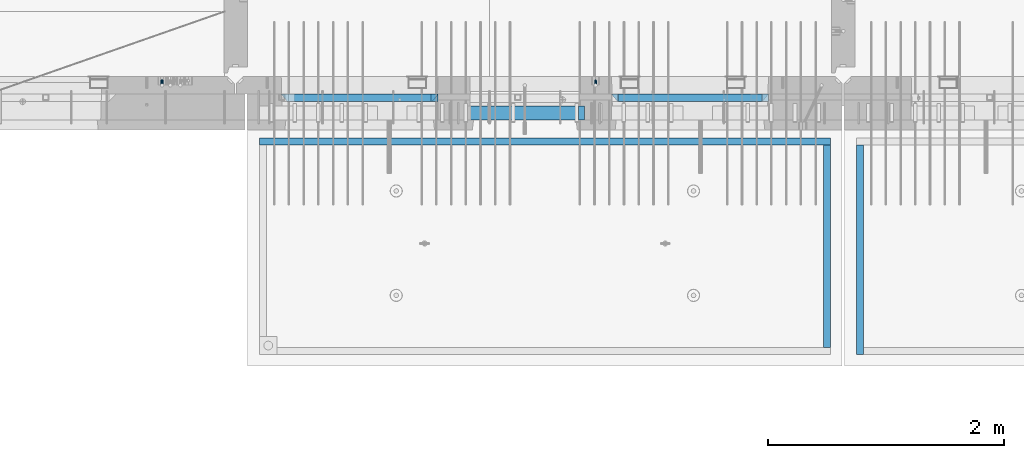
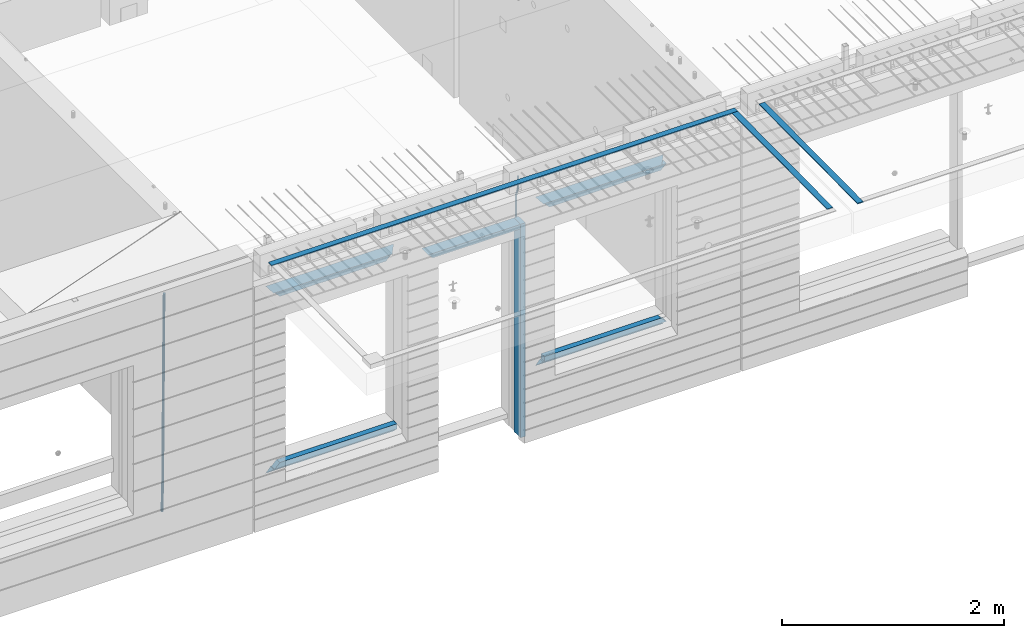
# One storey, part 90 of 334: 15 beams, 4 elements without a shape of their own.
"""IFC2X3 building model written with IfcOpenShell, lengths in millimetres."""

import ifcopenshell
import ifcopenshell.guid

model = None  # the IFC model being written
_history = None  # IfcOwnerHistory: only IFC2X3 demands one
_inside = {}  # id of a spatial element -> (the spatial element, [elements in it])
_under = {}  # id of a project, library or spatial element -> (it, [spatial elements below it])
_declared = {}  # id of a project -> (the project, [libraries it declares])
_typed = {}  # id of a type object -> (the type object, [elements of that type])
_made_of = {}  # id of a material, layer set ... -> (it, [elements and type objects made of it])


def new_model(schema):
    """Start an empty IFC model of exactly this schema.

    Asked for "IFC4X3", IfcOpenShell would pick the latest addendum, in which some entities
    have other attributes; the version numbers below select the first issue.
    IFC2X3 requires an IfcOwnerHistory on every rooted entity: one is made here for all.
    """
    global model, _history
    if schema == "IFC4X3":
        model = ifcopenshell.file(schema_version=(4, 3, 0, 0))
    else:
        model = ifcopenshell.file(schema=schema)
    _inside.clear()
    _under.clear()
    _declared.clear()
    _typed.clear()
    _made_of.clear()
    _history = None
    if model.schema == "IFC2X3":
        org = make("IfcOrganization", Name="unknown")
        user = make(
            "IfcPersonAndOrganization",
            ThePerson=make("IfcPerson", FamilyName="unknown"),
            TheOrganization=org,
        )
        app = make(
            "IfcApplication",
            ApplicationDeveloper=org,
            Version="unknown",
            ApplicationFullName="unknown",
            ApplicationIdentifier="unknown",
        )
        _history = make(
            "IfcOwnerHistory",
            OwningUser=user,
            OwningApplication=app,
            ChangeAction="ADDED",
            CreationDate=0,
        )
    return model


def make(cls, **values):
    """One entity of the class cls with the attributes given. An attribute that is None is left unset."""
    return model.create_entity(
        cls, **{name: value for name, value in values.items() if value is not None}
    )


def rooted(cls, **values):
    """An entity with a GlobalId (a new one), such as an element, a storey or a relation."""
    return make(cls, GlobalId=ifcopenshell.guid.new(), OwnerHistory=_history, **values)


def si_unit(unit_type, name, prefix=None):
    """IfcSIUnit, for example si_unit("LENGTHUNIT", "METRE", prefix="MILLI")."""
    return make("IfcSIUnit", UnitType=unit_type, Prefix=prefix, Name=name)


def assignment(units):
    """IfcUnitAssignment: the units of a project."""
    return None if units is None else make("IfcUnitAssignment", Units=units)


def point(xyz):
    """IfcCartesianPoint."""
    return None if xyz is None else make("IfcCartesianPoint", Coordinates=xyz)


def direction(xyz):
    """IfcDirection."""
    return None if xyz is None else make("IfcDirection", DirectionRatios=xyz)


def frame(location, z_axis=None, x_axis=None):
    """IfcAxis2Placement3D, a coordinate frame: its origin and axes. An axis left out is left unset."""
    return make(
        "IfcAxis2Placement3D",
        Location=point(location),
        Axis=direction(z_axis),
        RefDirection=direction(x_axis),
    )


def origin_with_axes():
    """The frame at (0, 0, 0) with the z axis (0, 0, 1) and the x axis (1, 0, 0) written out."""
    return frame((0.0, 0.0, 0.0), z_axis=(0.0, 0.0, 1.0), x_axis=(1.0, 0.0, 0.0))


def place(relative_to, where):
    """IfcLocalPlacement: puts the frame where relative to a parent placement (None: the world)."""
    return make(
        "IfcLocalPlacement", PlacementRelTo=relative_to, RelativePlacement=where
    )


def context(
    kind, dimensions, precision=None, world=None, true_north=None, identifier=None
):
    """IfcGeometricRepresentationContext, for example the 3D "Model" context."""
    return make(
        "IfcGeometricRepresentationContext",
        ContextIdentifier=identifier,
        ContextType=kind,
        CoordinateSpaceDimension=dimensions,
        Precision=precision,
        WorldCoordinateSystem=world,
        TrueNorth=true_north,
    )


def subcontext(parent, identifier, kind, view, scale=None):
    """IfcGeometricRepresentationSubContext, for example "Body" below "Model"."""
    return make(
        "IfcGeometricRepresentationSubContext",
        ContextIdentifier=identifier,
        ContextType=kind,
        ParentContext=parent,
        TargetScale=scale,
        TargetView=view,
    )


def project(units=None, contexts=None):
    """IfcProject with its units and contexts."""
    return rooted(
        "IfcProject",
        Name="project",
        RepresentationContexts=contexts,
        UnitsInContext=assignment(units),
    )


def spatial(cls, under=None, at=None, **own):
    """A site, building, storey or space (cls), placed at a placement, below another one or the project."""
    s = rooted(cls, ObjectPlacement=at, **own)
    if under is not None:
        _under.setdefault(under.id(), (under, []))[1].append(s)
    return s


def faces_of(points, faces, orient=None, outer=None):
    """IfcFace entities. A face is a list of loops; a loop is a list of indices into points, from 0.

    orient and outer hold one flag for each loop. By default every Orientation is true, the
    first loop of a face is its IfcFaceOuterBound and the others are IfcFaceBound.
    """
    made = []
    for i, loops in enumerate(faces):
        bounds = []
        for j, loop in enumerate(loops):
            is_outer = j == 0 if outer is None else outer[i][j]
            bounds.append(
                make(
                    "IfcFaceOuterBound" if is_outer else "IfcFaceBound",
                    Bound=make("IfcPolyLoop", Polygon=[points[k] for k in loop]),
                    Orientation=True if orient is None else orient[i][j],
                )
            )
        made.append(make("IfcFace", Bounds=bounds))
    return made


def faceted_brep(points, faces, orient=None, outer=None, voids=None):
    """IfcFacetedBrep: a solid bounded by flat faces; with voids (closed shells), ...WithVoids."""
    shared = [point(p) for p in points]
    hull = make("IfcClosedShell", CfsFaces=faces_of(shared, faces, orient, outer))
    if voids is None:
        return make("IfcFacetedBrep", Outer=hull)
    return make(
        "IfcFacetedBrepWithVoids",
        Outer=hull,
        Voids=[
            make(cls, CfsFaces=faces_of(shared, fs, o, b)) for cls, fs, o, b in voids
        ],
    )


def shape(context_of_items, identifier, shape_type, items):
    """IfcShapeRepresentation: the items that make up one representation, for example the "Body"."""
    return make(
        "IfcShapeRepresentation",
        ContextOfItems=context_of_items,
        RepresentationIdentifier=identifier,
        RepresentationType=shape_type,
        Items=items,
    )


def material(Name=None, Category=None):
    """IfcMaterial."""
    return make("IfcMaterial", Name=Name, Category=Category)


def made_of(thing, what):
    """Note that an element or type object is made of a material, layer set ...; save() writes the relation."""
    if what is not None:
        _made_of.setdefault(what.id(), (what, []))[1].append(thing)
    return thing


def type_object(cls, material=None, **own):
    """A type object (cls), such as IfcWallType, which elements share."""
    return made_of(rooted(cls, **own), material)


def element(
    cls,
    number,
    at=None,
    inside=None,
    cuts=None,
    type_object=None,
    material=None,
    context=None,
    identifier="Body",
    shape_type=None,
    held_by="IfcProductDefinitionShape",
    body=None,
    shapes=None,
    **own,
):
    """One element of the class cls, such as IfcWall. Its Tag is "e" and its number.

    at: its placement. inside: the storey or other place that contains it. cuts: it is an
    opening in that element (IfcRelVoidsElement). A single representation is given by context,
    identifier, shape_type and body (its items); several are given by shapes. held_by: the class
    of the entity that holds the representations. save() writes the other relations.
    """
    e = rooted(cls, Tag="e%d" % number, ObjectPlacement=at, **own)
    if body is not None:
        shapes = [shape(context, identifier, shape_type, body)]
    if shapes is not None:
        e.Representation = make(held_by, Representations=shapes)
    if inside is not None:
        _inside.setdefault(inside.id(), (inside, []))[1].append(e)
    if cuts is not None:
        rooted(
            "IfcRelVoidsElement", RelatingBuildingElement=cuts, RelatedOpeningElement=e
        )
    if type_object is not None:
        _typed.setdefault(type_object.id(), (type_object, []))[1].append(e)
    return made_of(e, material)


def aggregate(whole, parts):
    """IfcRelAggregates: a whole, such as a stair, and the parts it consists of."""
    return rooted("IfcRelAggregates", RelatingObject=whole, RelatedObjects=parts)


def save(model, path):
    """Write the relations noted so far, then the file.

    IfcRelAggregates (storeys below a building ...), IfcRelContainedInSpatialStructure (elements
    in a storey), IfcRelDefinesByType, IfcRelAssociatesMaterial and IfcRelDeclares: one each for
    every whole, place, type object, material and project.
    """
    for whole, parts in _under.values():
        aggregate(whole, parts)
    for where, things in _inside.values():
        rooted(
            "IfcRelContainedInSpatialStructure",
            RelatedElements=things,
            RelatingStructure=where,
        )
    for kind, things in _typed.values():
        rooted("IfcRelDefinesByType", RelatedObjects=things, RelatingType=kind)
    for what, things in _made_of.values():
        rooted("IfcRelAssociatesMaterial", RelatedObjects=things, RelatingMaterial=what)
    for by, libraries in _declared.values():
        rooted("IfcRelDeclares", RelatingContext=by, RelatedDefinitions=libraries)
    model.write(path)


model = new_model("IFC2X3")

# Units and contexts
model_context = context("Model", 3, precision=1e-05, world=origin_with_axes())
body_context = subcontext(model_context, "Body", "Model", "MODEL_VIEW")
ifc_project = project(units=[si_unit("LENGTHUNIT", "METRE", prefix="MILLI"), si_unit("AREAUNIT", "SQUARE_METRE"), si_unit("VOLUMEUNIT", "CUBIC_METRE"), si_unit("MASSUNIT", "GRAM", prefix="KILO"), si_unit("TIMEUNIT", "SECOND"), si_unit("PLANEANGLEUNIT", "RADIAN"), si_unit("SOLIDANGLEUNIT", "STERADIAN"), si_unit("THERMODYNAMICTEMPERATUREUNIT", "DEGREE_CELSIUS"), si_unit("LUMINOUSINTENSITYUNIT", "LUMEN")], contexts=[model_context])

# Site, building, storey
site_placement = place(None, origin_with_axes())
site = spatial("IfcSite", under=ifc_project, at=site_placement, CompositionType="ELEMENT")
building_placement = place(site_placement, origin_with_axes())
building = spatial("IfcBuilding", under=site, at=building_placement, CompositionType="ELEMENT")
storey_placement = place(building_placement, origin_with_axes())
storey = spatial("IfcBuildingStorey", under=building, at=storey_placement, Name="3", CompositionType="ELEMENT", Elevation=0.0)

# Assembly, beam
assembly_1_placement = place(storey_placement, origin_with_axes())
assembly_1 = element("IfcElementAssembly", 1, at=assembly_1_placement, inside=storey, AssemblyPlace="NOTDEFINED", PredefinedType="REINFORCEMENT_UNIT")
ifc_material_1 = material()
beam_type_1 = type_object("IfcBeamType", Name="D20", PredefinedType="NOTDEFINED")
beam_1_placement = place(assembly_1_placement, frame((19710.0073333522, 7925.0, 90407.5000058722), z_axis=(0.000415599999849905, 0.999999913638203, 4.76000000899737e-07), x_axis=(0.0, 0.0, -1.0)))
beam_1 = element("IfcBeam", 2, at=beam_1_placement, type_object=beam_type_1, material=ifc_material_1, Name="JM20", ObjectType="D20", context=body_context, shape_type="Brep", body=[
    faceted_brep([(0.0, -10.0, 0.0), (-4.19531716033816e-08, -7.07106781186667, -7.07106781187031), (113.248091332178, -7.0710684840451, -7.0710678117357), (113.248091314759, -10.0000006713562, -2.51020537689328e-10), (0.0, 0.0, -10.0), (113.248091374131, -6.72178430249915e-07, -9.99999999986903), (4.196772351861e-08, 7.07106781186303, -7.07106781186667), (113.248091416113, 7.07106713968824, -7.07106781173934), (0.0, 10.0, 0.0), (113.248091433488, 9.99999932782521, 1.30967237055302e-10), (4.196772351861e-08, 7.07106781185939, 7.07106781185939), (113.248091416113, 7.0710671396846, 7.071067811994), (0.0, 0.0, 10.0), (113.248091374131, -6.72174792271107e-07, 10.0000000001273), (-4.19531716033816e-08, -7.07106781187031, 7.07106781185939), (113.248091332178, -7.0710684840451, 7.071067811994), (130.699843527167, -7.06993249763036, -4.33745683788584), (128.538066582521, -9.99900540317321, 2.39499413731755), (131.594536475241, 0.00119355250353692, -7.12624594330919), (130.698046432328, 7.07220300913468, -4.33773834422391), (128.535525107087, 10.0009944322555, 2.39459602660281), (126.373748162892, 7.07192152754578, 9.1270470011732), (125.479055214906, 0.000795477419160306, 11.9158361066184), (126.37554525779, -7.07021397921199, 9.12732850753673), (240.336258550378, -7.05529970173666, 30.8729495437874), (238.174481606227, -9.98437260450009, 37.6054005176375), (241.230951498423, 0.0158263482953771, 28.0841604381058), (240.334461455612, 7.0868358050102, 30.8726680369582), (238.171940130502, 10.0156272283348, 37.6050024077231), (236.010163186409, 7.08655432384694, 44.3374533824244), (235.115470238379, 0.0154282738185429, 47.1262424881097), (236.011960281176, -7.05558118289991, 44.3377348892536), (253.461915329972, -7.05444528127919, 32.9289287376414), (253.46191532613, -9.98337746617108, 39.9999965521893), (253.461915339081, 0.0166225284556276, 29.9999965443676), (253.461915348205, 7.08769034247234, 32.9289287273205), (253.461915352003, 10.0166225357716, 39.9999965370152), (253.461915348293, 7.08769035281148, 47.0710643509774), (253.461915339183, 0.0166225430875784, 49.999996544273), (253.46191533003, -7.05444527093641, 47.0710643613093), (1617.47998045172, -7.05444857276962, 32.9289287369675), (1617.47998044467, -9.98338075699212, 39.9999965504549), (1617.47998046874, 0.0166192374708771, 29.9999965449206), (1617.47998048575, 7.08768705096008, 32.9289287291404), (1617.47998049279, 10.0166192430079, 39.9999965393854), (1617.47998048575, 7.08768705878902, 47.071064352871), (1617.47998046874, 0.0166192485448846, 49.9999965449197), (1617.47998045172, -7.05444856494069, 47.0710643606981)], [[[0, 1, 2, 3]], [[1, 4, 5, 2]], [[4, 6, 7, 5]], [[6, 8, 9, 7]], [[8, 10, 11, 9]], [[10, 12, 13, 11]], [[12, 14, 15, 13]], [[14, 0, 3, 15]], [[14, 12, 10, 8, 6, 4, 1, 0]], [[3, 2, 16, 17]], [[2, 5, 18, 16]], [[5, 7, 19, 18]], [[7, 9, 20, 19]], [[9, 11, 21, 20]], [[11, 13, 22, 21]], [[13, 15, 23, 22]], [[15, 3, 17, 23]], [[17, 16, 24, 25]], [[16, 18, 26, 24]], [[18, 19, 27, 26]], [[19, 20, 28, 27]], [[20, 21, 29, 28]], [[21, 22, 30, 29]], [[22, 23, 31, 30]], [[23, 17, 25, 31]], [[25, 24, 32, 33]], [[24, 26, 34, 32]], [[26, 27, 35, 34]], [[27, 28, 36, 35]], [[28, 29, 37, 36]], [[29, 30, 38, 37]], [[30, 31, 39, 38]], [[31, 25, 33, 39]], [[33, 32, 40, 41]], [[32, 34, 42, 40]], [[34, 35, 43, 42]], [[35, 36, 44, 43]], [[36, 37, 45, 44]], [[37, 38, 46, 45]], [[38, 39, 47, 46]], [[39, 33, 41, 47]], [[42, 43, 44, 45, 46, 47, 41, 40]]]),
])

assembly_2_placement = place(storey_placement, origin_with_axes())
assembly_2 = element("IfcElementAssembly", 3, at=assembly_2_placement, inside=storey, AssemblyPlace="NOTDEFINED", PredefinedType="REINFORCEMENT_UNIT")
beam_type_2 = type_object("IfcBeamType", Name="D25", PredefinedType="NOTDEFINED")
beam_2_placement = place(assembly_2_placement, frame((16034.9999999961, 7965.00000227913, 87990.0), z_axis=(0.00020576299992186, -0.999642804629538, -0.0267249099901004), x_axis=(-4.30000201928125e-08, -0.0267249099948059, 0.999642825806181)))
beam_2 = element("IfcBeam", 4, at=beam_2_placement, type_object=beam_type_2, material=ifc_material_1, Name="JM25", ObjectType="D25", context=body_context, shape_type="Brep", body=[
    faceted_brep([(-7.41420080885291e-08, -12.5, -3.63797880709171e-12), (-6.42030499875546e-08, -10.8253175473074, -6.25000000000364), (60.4103898235917, -10.8253175318459, -6.2499999938409), (60.4103898269532, -12.4999999845422, 6.16273609921336e-09), (-3.70782800018787e-08, -6.25000000000364, -10.8253175473074), (60.4103898202884, -6.24999998454587, -10.8253175411446), (-1.45519152283669e-11, -3.63797880709171e-12, -12.5), (60.4103898179019, 1.54577719513327e-08, -12.4999999938373), (3.70637280866504e-08, 6.25, -10.8253175473074), (60.410389817087, 6.25000001545777, -10.825317541141), (6.42030499875546e-08, 10.8253175473001, -6.25000000000364), (60.410389818062, 10.8253175627578, -6.24999999383726), (7.41420080885291e-08, 12.4999999999927, 0.0), (60.4103898205503, 12.5000000154541, 6.16273609921336e-09), (6.42176019027829e-08, 10.8253175473001, 6.24999999999636), (60.4103898238973, 10.8253175627651, 6.2500000061591), (3.70928319171071e-08, 6.24999999999636, 10.8253175473037), (60.4103898272151, 6.25000001546141, 10.8253175534664), (1.45519152283669e-11, -3.63797880709171e-12, 12.4999999999964), (60.4103898296162, 1.54541339725256e-08, 12.5000000061591), (-3.7049176171422e-08, -6.25000000000364, 10.8253175473001), (60.4103898304165, -6.24999998454587, 10.8253175534701), (-6.41884980723262e-08, -10.8253175473074, 6.25), (60.4103898294561, -10.8253175318459, 6.25000000616637), (61.0324985728803, -10.8253175316895, -6.24999999377542), (60.991802792938, -12.4999999843931, 6.22458173893392e-09), (61.0622854283865, -6.24999998437852, -10.8253175410755), (61.0731819955545, 1.5628756955266e-08, -12.4999999937718), (61.0622685480339, 6.25000001562512, -10.8253175410791), (61.032469335245, 10.8253175629216, -6.24999999377178), (60.9917690322181, 12.5000000156033, 6.22458173893392e-09), (60.9510732522613, 10.8253175629034, 6.25000000621731), (60.9212863967696, 6.25000001558874, 10.8253175535247), (60.9103898296162, 1.55814632307738e-08, 12.5000000062137), (60.9213032771368, -6.24999998441126, 10.8253175535174), (60.9511024898966, -10.8253175317113, 6.25000000621731), (61.6545545670233, -10.8253158516927, -6.24189838219536), (61.573166454793, -12.499998414296, 0.00757164385504439), (61.7141257553885, -6.24999822394238, -10.8168280205282), (61.7359179680789, 1.80548886419274e-06, -12.491368569139), (61.7140919992817, 6.25000177601396, -10.8168282403167), (61.6544960997562, 10.8253192428383, -6.2418987628771), (61.5730989426083, 12.5000015856094, 0.0075712042817031), (61.4917108303925, 10.8253190230062, 6.25704123032847), (61.4321396420273, 6.25000139525582, 10.8319708686649), (61.4103474293224, 1.36582457344048e-06, 12.5065114172721), (61.4321733981196, -6.24999860470052, 10.8319710884571), (61.4917692976451, -10.8253160715249, 6.25704161101385), (176.524302641745, -10.8250056210964, -4.74584321979273), (176.442914529529, -12.4996881836996, 1.50362680625403), (176.583873830095, -6.24968799334965, -9.3207728581292), (176.605666042786, 0.000312036081595579, -10.9953134067364), (176.583840074018, 6.25031200660669, -9.32077307791769), (176.524244174492, 10.8256294734347, -4.74584360047811), (176.44284701733, 12.5003118162058, 1.50362636668069), (176.361458905099, 10.8256292535989, 7.75309639272746), (176.301887716749, 6.25031162585219, 12.3280260310676), (176.280095504058, 0.000311596420942806, 14.0025665796711), (176.301921472827, -6.24968837410415, 12.3280262508561), (176.361517372367, -10.8250058409321, 7.75309677341284), (177.085397012124, -10.8250041057399, -4.73853556792164), (176.983633547483, -12.4996867233749, 1.51066909103247), (177.159881729676, -6.24968643771717, -9.31327097355097), (177.187129580227, 0.000313606451527448, -10.987740468332), (177.159839524218, 6.25031356221734, -9.31327130338468), (177.085323910098, 10.8256309887511, -4.73853613920801), (176.983549136537, 12.5003132764905, 1.51066843136869), (176.881785671867, 10.8256306588555, 7.7598730903228), (176.80730095433, 6.25031299082912, 12.3346084959521), (176.780053103794, 0.000312946667690994, 14.0090779907332), (176.807343159802, -6.2496870091054, 12.3346088257895), (176.881858773908, -10.8250044356355, 7.7598736616128), (177.646431799818, -10.8250018318176, -4.72756919822132), (177.524295146417, -12.4996845320202, 1.52123723245313), (177.735828462886, -6.24968410334986, -9.30201312475765), (177.768531371941, 0.00031596292683389, -10.9763759912421), (177.735777808921, 6.25031589654827, -9.30201361973741), (177.646344064575, 10.8256332626152, -4.72757005553649), (177.524193838486, 12.5003154677688, 1.52123624250817), (177.402057185071, 10.8256327675663, 7.77004267317898), (177.312660521988, 6.2503150390985, 12.3444865997226), (177.279957612933, 0.00031497282179771, 14.0188494661961), (177.312711175953, -6.24968496079964, 12.3444870946951), (177.402144920314, -10.8250023268702, 7.77004353049415), (299.377443161706, -10.8245084454466, -2.34813158632096), (299.255306508276, -12.4991911456491, 3.90067484435349), (299.466839824803, -6.24919071697514, -6.92257551286093), (299.499542733873, 0.0008093492979242, -8.59693837933446), (299.466789170867, 6.250809282923, -6.92257600783341), (299.377355426492, 10.8261266489935, -2.34813244364341), (299.255205200388, 12.5008088541435, 3.90067385440125), (299.133068546944, 10.826126153941, 10.1494802850757), (299.043671883861, 6.25080842546959, 14.7239242116229), (299.010968974762, 0.000808359200163977, 16.3982870780892), (299.043722537797, -6.24919157442127, 14.7239247065918), (299.133156282158, -10.8245089404954, 10.1494811423981), (299.98561436501, -10.8245059804758, -2.33624385599614), (299.97179243555, -12.4991882411778, 3.91467976726199), (299.995742293278, -6.24918857328521, -6.91223722345239), (299.999447243041, 0.000811375455668895, -8.58716690387519), (299.995736475976, 6.25081142679483, -6.91223684201032), (299.985604289133, 10.8261291142808, -2.33624319533556), (299.971750386685, 12.5008117588586, 3.91467993563856), (299.957928457196, 10.8261294971744, 10.1656035610831), (299.947800528913, 6.25081208998381, 14.7415969285394), (299.944095579151, 0.00081214124293183, 16.4165266089549), (299.947806346216, -6.24918791008895, 14.7415965471009), (299.957938533058, -10.8245055975785, 10.1656029004225), (300.593832239858, -10.8245078794353, -2.34543881707941), (300.688302931099, -12.4991904788549, 3.90384712594823), (300.524685350189, -6.24919022474205, -6.92023371784308), (300.499390115292, 0.000809814544481924, -8.59472497713432), (300.524724372954, 6.25080977519247, -6.92023401429469), (300.593899829313, 10.8261272150703, -2.34543933054374), (300.688380976673, 12.5008095210287, 3.90384653304136), (300.782851667915, 10.8261269216127, 10.1531324760799), (300.851998557599, 6.25080926691589, 14.7279273768363), (300.877293792495, 0.000809227632998955, 16.4024186361276), (300.851959534804, -6.24919073302226, 14.7279276732806), (300.782784078474, -10.8245081728965, 10.153132989537), (2293.32930409742, -10.8307295605009, -32.4713622331001), (2293.42377478865, -12.5054121599169, -26.2220762900724), (2293.26015720774, -6.2554119058077, -37.0461571338565), (2293.23486197284, -0.00541186651753378, -38.7206483931477), (2293.26019623051, 6.24458809413409, -37.0461574303008), (2293.32937168686, 10.8199055340046, -32.4713627465644), (2293.42385283421, 12.4945878399631, -26.2220768829684), (2293.51832352545, 10.8199052405434, -19.972790939948), (2293.58747041514, 6.24458758585388, -15.3979960391844), (2293.61276565003, -0.00541245343265473, -13.7235047798931), (2293.58743139236, -6.25541241408428, -15.3979957427327), (2293.51825593603, -10.8307298539585, -19.9727904264691), (2294.0420846676, -10.8307317859326, -32.4821379598216), (2294.03681932652, -12.5054140739521, -26.2313442200393), (2294.06778164886, -6.2554144273563, -37.0583666982457), (2294.10702478497, -0.00541458957013674, -38.7338336404937), (2294.14929890928, 6.24458531819619, -37.0595987724118), (2294.18327670435, 10.8199028679592, -32.4842719748667), (2294.1998538474, 12.4945854171456, -26.2338083683717), (2294.19458850632, 10.819903129126, -19.9830146285858), (2294.16889152506, 6.24458577054975, -15.4067858901581), (2294.12964838895, -0.0054140672327776, -13.7313189479173), (2294.08737426462, -6.2554139749991, -15.4055538159919), (2294.05339646956, -10.8307315247621, -19.9808806135297), (2294.75482297382, -10.84002603931, -32.4726521173216), (2294.64982751427, -12.513407826169, -26.2231856868602), (2294.87535820232, -6.26594539088183, -37.0476186524102), (2294.97913588268, -0.0167870967634371, -38.7222267036377), (2295.0383488692, 6.23299192477134, -37.0477663960555), (2295.03713108998, 10.8087684320271, -32.4729080168181), (2294.97580884799, 12.4844668051373, -26.2234811741473), (2294.87081338844, 10.8110850182784, -19.9740147436787), (2294.7502781599, 6.23700436985018, -15.3990482086047), (2294.64650047956, -0.0121539242718427, -13.7244401573698), (2294.58728749304, -6.26193294580662, -15.3989004649666), (2294.58850527227, -10.8377094530588, -19.9737588441894), (2316.44667268227, -11.1228921988077, -32.1839550346631), (2316.34167722271, -12.7962739856739, -25.9344886042054), (2316.56720791078, -6.54881155039038, -36.7589215697517), (2316.67098559113, -0.299653256264719, -38.4335296209792), (2316.73019857766, 5.95012576527006, -36.759069313397), (2316.72898079845, 10.5259022725259, -32.1842109341669), (2316.66765855643, 12.2016006456361, -25.9347840914961), (2316.56266309689, 10.5282188587698, -19.6853176610275), (2316.44212786836, 5.95413821035254, -15.1103511259389), (2316.33835018802, -0.295020083769487, -13.4357430747186), (2316.27913720149, -6.54479910530426, -15.1102033823008), (2316.28035498071, -11.1205756125637, -19.685061761531), (2317.13234804722, -11.1318335458927, -32.1748293731798), (2317.04181141085, -12.8054038787741, -25.9251705100723), (2317.2154741603, -6.5572650749491, -36.7502937866229), (2317.26891617525, -0.307450393454928, -38.4255717558117), (2317.27835434731, 5.94297770185585, -36.7517739018112), (2317.24125972588, 10.5192220504723, -32.1773930078925), (2317.16757178486, 12.1950816748285, -25.9281307404563), (2317.0770351485, 10.5215113419545, -19.6784718773561), (2316.99390903539, 5.94694287101083, -15.1030074639057), (2316.94046702047, -0.302871810494253, -13.4277294947169), (2316.9310288484, -6.55329990579412, -15.1015273487101), (2316.96812346982, -11.1295442544142, -19.6759082426288), (2317.81808136747, -11.1298054502913, -32.1659056455355), (2317.74200467508, -12.803315894289, -25.9160547315114), (2317.86379538118, -6.55536082026447, -36.7418676070083), (2317.8668976831, -0.305700748642266, -38.417815303761), (2317.82655701396, 5.94458339541234, -36.7446799039099), (2317.75358262347, 10.5207330230332, -32.1707766866384), (2317.66752794063, 12.1965725370646, -25.9216793252963), (2317.59145124823, 10.5230620930706, -19.6718284112721), (2317.54573723453, 5.94861746304377, -15.0958664497994), (2317.54263493262, -0.301042608574789, -13.4199187530394), (2317.58297560175, -6.55132675263303, -15.0930541529051), (2317.65594999224, -11.1274763802539, -19.6669573701693), (2417.81884292323, -10.831603083323, -30.8687911350135), (2417.74276623082, -12.505113527317, -24.618940220982), (2417.86455693691, -6.25715845329614, -35.4447530964935), (2417.86765923884, -0.00749838167394046, -37.1207007932499), (2417.82731856969, 6.24278576237703, -35.4475653933878), (2417.75434417921, 10.8189353900088, -30.8736621761236), (2417.66828949639, 12.494774904033, -24.6245648147851), (2417.59221280397, 10.8212644600353, -18.3747139007501), (2417.54649879028, 6.2468198300121, -13.79875193927), (2417.54339648837, -0.00284024161010166, -12.1228042425173), (2417.5837371575, -6.25312438566107, -13.795939642383), (2417.65671154798, -10.8292740132893, -18.3698428596399)], [[[0, 1, 2, 3]], [[1, 4, 5, 2]], [[4, 6, 7, 5]], [[6, 8, 9, 7]], [[8, 10, 11, 9]], [[10, 12, 13, 11]], [[12, 14, 15, 13]], [[14, 16, 17, 15]], [[16, 18, 19, 17]], [[18, 20, 21, 19]], [[20, 22, 23, 21]], [[22, 0, 3, 23]], [[22, 20, 18, 16, 14, 12, 10, 8, 6, 4, 1, 0]], [[3, 2, 24, 25]], [[2, 5, 26, 24]], [[5, 7, 27, 26]], [[7, 9, 28, 27]], [[9, 11, 29, 28]], [[11, 13, 30, 29]], [[13, 15, 31, 30]], [[15, 17, 32, 31]], [[17, 19, 33, 32]], [[19, 21, 34, 33]], [[21, 23, 35, 34]], [[23, 3, 25, 35]], [[25, 24, 36, 37]], [[24, 26, 38, 36]], [[26, 27, 39, 38]], [[27, 28, 40, 39]], [[28, 29, 41, 40]], [[29, 30, 42, 41]], [[30, 31, 43, 42]], [[31, 32, 44, 43]], [[32, 33, 45, 44]], [[33, 34, 46, 45]], [[34, 35, 47, 46]], [[35, 25, 37, 47]], [[37, 36, 48, 49]], [[36, 38, 50, 48]], [[38, 39, 51, 50]], [[39, 40, 52, 51]], [[40, 41, 53, 52]], [[41, 42, 54, 53]], [[42, 43, 55, 54]], [[43, 44, 56, 55]], [[44, 45, 57, 56]], [[45, 46, 58, 57]], [[46, 47, 59, 58]], [[47, 37, 49, 59]], [[49, 48, 60, 61]], [[48, 50, 62, 60]], [[50, 51, 63, 62]], [[51, 52, 64, 63]], [[52, 53, 65, 64]], [[53, 54, 66, 65]], [[54, 55, 67, 66]], [[55, 56, 68, 67]], [[56, 57, 69, 68]], [[57, 58, 70, 69]], [[58, 59, 71, 70]], [[59, 49, 61, 71]], [[61, 60, 72, 73]], [[60, 62, 74, 72]], [[62, 63, 75, 74]], [[63, 64, 76, 75]], [[64, 65, 77, 76]], [[65, 66, 78, 77]], [[66, 67, 79, 78]], [[67, 68, 80, 79]], [[68, 69, 81, 80]], [[69, 70, 82, 81]], [[70, 71, 83, 82]], [[71, 61, 73, 83]], [[73, 72, 84, 85]], [[72, 74, 86, 84]], [[74, 75, 87, 86]], [[75, 76, 88, 87]], [[76, 77, 89, 88]], [[77, 78, 90, 89]], [[78, 79, 91, 90]], [[79, 80, 92, 91]], [[80, 81, 93, 92]], [[81, 82, 94, 93]], [[82, 83, 95, 94]], [[83, 73, 85, 95]], [[85, 84, 96, 97]], [[84, 86, 98, 96]], [[86, 87, 99, 98]], [[87, 88, 100, 99]], [[88, 89, 101, 100]], [[89, 90, 102, 101]], [[90, 91, 103, 102]], [[91, 92, 104, 103]], [[92, 93, 105, 104]], [[93, 94, 106, 105]], [[94, 95, 107, 106]], [[95, 85, 97, 107]], [[97, 96, 108, 109]], [[96, 98, 110, 108]], [[98, 99, 111, 110]], [[99, 100, 112, 111]], [[100, 101, 113, 112]], [[101, 102, 114, 113]], [[102, 103, 115, 114]], [[103, 104, 116, 115]], [[104, 105, 117, 116]], [[105, 106, 118, 117]], [[106, 107, 119, 118]], [[107, 97, 109, 119]], [[109, 108, 120, 121]], [[108, 110, 122, 120]], [[110, 111, 123, 122]], [[111, 112, 124, 123]], [[112, 113, 125, 124]], [[113, 114, 126, 125]], [[114, 115, 127, 126]], [[115, 116, 128, 127]], [[116, 117, 129, 128]], [[117, 118, 130, 129]], [[118, 119, 131, 130]], [[119, 109, 121, 131]], [[121, 120, 132, 133]], [[120, 122, 134, 132]], [[122, 123, 135, 134]], [[123, 124, 136, 135]], [[124, 125, 137, 136]], [[125, 126, 138, 137]], [[126, 127, 139, 138]], [[127, 128, 140, 139]], [[128, 129, 141, 140]], [[129, 130, 142, 141]], [[130, 131, 143, 142]], [[131, 121, 133, 143]], [[133, 132, 144, 145]], [[132, 134, 146, 144]], [[134, 135, 147, 146]], [[135, 136, 148, 147]], [[136, 137, 149, 148]], [[137, 138, 150, 149]], [[138, 139, 151, 150]], [[139, 140, 152, 151]], [[140, 141, 153, 152]], [[141, 142, 154, 153]], [[142, 143, 155, 154]], [[143, 133, 145, 155]], [[145, 144, 156, 157]], [[144, 146, 158, 156]], [[146, 147, 159, 158]], [[147, 148, 160, 159]], [[148, 149, 161, 160]], [[149, 150, 162, 161]], [[150, 151, 163, 162]], [[151, 152, 164, 163]], [[152, 153, 165, 164]], [[153, 154, 166, 165]], [[154, 155, 167, 166]], [[155, 145, 157, 167]], [[157, 156, 168, 169]], [[156, 158, 170, 168]], [[158, 159, 171, 170]], [[159, 160, 172, 171]], [[160, 161, 173, 172]], [[161, 162, 174, 173]], [[162, 163, 175, 174]], [[163, 164, 176, 175]], [[164, 165, 177, 176]], [[165, 166, 178, 177]], [[166, 167, 179, 178]], [[167, 157, 169, 179]], [[169, 168, 180, 181]], [[168, 170, 182, 180]], [[170, 171, 183, 182]], [[171, 172, 184, 183]], [[172, 173, 185, 184]], [[173, 174, 186, 185]], [[174, 175, 187, 186]], [[175, 176, 188, 187]], [[176, 177, 189, 188]], [[177, 178, 190, 189]], [[178, 179, 191, 190]], [[179, 169, 181, 191]], [[181, 180, 192, 193]], [[180, 182, 194, 192]], [[182, 183, 195, 194]], [[183, 184, 196, 195]], [[184, 185, 197, 196]], [[185, 186, 198, 197]], [[186, 187, 199, 198]], [[187, 188, 200, 199]], [[188, 189, 201, 200]], [[189, 190, 202, 201]], [[190, 191, 203, 202]], [[191, 181, 193, 203]], [[194, 195, 196, 197, 198, 199, 200, 201, 202, 203, 193, 192]]]),
])
aggregate(assembly_2, [beam_2])

assembly_3_placement = place(storey_placement, origin_with_axes())
assembly_3 = element("IfcElementAssembly", 5, at=assembly_3_placement, inside=storey, AssemblyPlace="NOTDEFINED", PredefinedType="REINFORCEMENT_UNIT")
ifc_material_2 = material(Name="CONCRETE/Concrete_Undefined")
beam_type_3 = type_object("IfcBeamType", PredefinedType="NOTDEFINED")
beam_3_placement = place(assembly_3_placement, frame((21949.9413897781, 7420.05314849477, 90725.6636561746), z_axis=(2.93000000986506e-07, -0.00901322400064496, 0.999959380071525), x_axis=(3.25389999851993e-05, -0.999959379542196, -0.00901322399586982)))
beam_3 = element("IfcBeam", 6, at=beam_3_placement, type_object=beam_type_3, material=ifc_material_2, context=body_context, shape_type="Brep", body=[
    faceted_brep([(2.5465851649642e-11, 29.9999999999982, -4.99999999998545), (-2.91038304567337e-11, 29.9999999999982, 5.0), (1775.16788460852, 30.0000000000036, 5.0), (1775.16788460861, 30.0000000000036, -4.99999999998545), (-2.5465851649642e-11, -30.0000000000018, 5.0), (1775.16788460852, -29.9999999999927, 5.0), (2.72848410531878e-11, -30.0000000000018, -4.99999999998545), (1775.16788460861, -29.9999999999927, -4.99999999998545)], [[[0, 1, 2, 3]], [[1, 4, 5, 2]], [[4, 6, 7, 5]], [[6, 0, 3, 7]], [[5, 7, 3, 2]], [[6, 4, 1, 0]]]),
])
aggregate(assembly_3, [beam_3])

# Assembly, beams
assembly_4_placement = place(storey_placement, origin_with_axes())
assembly_4 = element("IfcElementAssembly", 7, at=assembly_4_placement, inside=storey, AssemblyPlace="NOTDEFINED", PredefinedType="REINFORCEMENT_UNIT")
beam_4_placement = place(assembly_4_placement, frame((21670.0013901233, 7419.93998011425, 90723.2790373903), z_axis=(-5.99999839176643e-09, -0.0089070149978186, 0.99996033175513), x_axis=(-7.26999998800451e-07, -0.999960331754865, -0.00890701499781462)))
beam_4 = element("IfcBeam", 8, at=beam_4_placement, type_object=beam_type_3, material=ifc_material_2, context=body_context, shape_type="Brep", body=[
    faceted_brep([(2.5465851649642e-11, 29.9999999999982, -4.99999999998545), (-2.91038304567337e-11, 29.9999999999982, 5.0), (1714.98205429674, 30.0, 5.00000000001455), (1714.98205429674, 30.0000000000036, -4.99999999998545), (-2.5465851649642e-11, -30.0000000000018, 5.0), (1714.98205429674, -30.0, 5.00000000001455), (2.72848410531878e-11, -30.0000000000018, -4.99999999998545), (1714.98205429674, -29.9999999999964, -4.99999999998545)], [[[0, 1, 2, 3]], [[1, 4, 5, 2]], [[4, 6, 7, 5]], [[6, 0, 3, 7]], [[5, 7, 3, 2]], [[6, 4, 1, 0]]]),
])
beam_5_placement = place(assembly_4_placement, frame((21700.0027302922, 7449.93184428734, 90723.6588442717), z_axis=(0.0, 0.0, 1.0), x_axis=(-0.999999999888168, 1.49249999983396e-05, 9.53000001204034e-07)))
beam_5 = element("IfcBeam", 9, at=beam_5_placement, type_object=beam_type_3, material=ifc_material_2, context=body_context, shape_type="Brep", body=[
    faceted_brep([(2.5465851649642e-11, 29.9999999999982, -4.99999999998545), (-2.91038304567337e-11, 29.9999999999982, 5.0), (4840.00999799337, 29.9999999999991, 5.0), (4840.00999799337, 29.9999999999982, -5.00000000001455), (-2.5465851649642e-11, -30.0000000000018, 5.0), (4840.00999799337, -30.0000000000009, 5.0), (2.72848410531878e-11, -30.0000000000018, -4.99999999998545), (4840.00999799337, -30.0000000000009, -5.0)], [[[0, 1, 2, 3]], [[1, 4, 5, 2]], [[4, 6, 7, 5]], [[6, 0, 3, 7]], [[5, 7, 3, 2]], [[6, 4, 1, 0]]]),
])
aggregate(assembly_4, [beam_4, beam_5])

# Beam
ifc_material_3 = material(Name="CONCRETE/C35/45")
beam_type_4 = type_object("IfcBeamType", PredefinedType="NOTDEFINED")
beam_6_placement = place(assembly_1_placement, frame((17044.9994828029, 7820.0, 90145.0), z_axis=(0.0, 0.0, -1.0), x_axis=(1.0, 0.0, 0.0)))
beam_6 = element("IfcBeam", 10, at=beam_6_placement, type_object=beam_type_4, material=ifc_material_3, Name="SK", context=body_context, shape_type="Brep", body=[
    faceted_brep([(0.0, -30.0, -30.0), (49.817662327685, -30.0, 30.0), (49.817662327685, 30.0, 30.0), (1330.00114440918, -30.0, -30.0), (1280.18348208149, -30.0, 30.0), (1280.18348208149, 30.0, 30.0)], [[[0, 1, 2]], [[1, 0, 3, 4]], [[2, 1, 4, 5]], [[0, 2, 5, 3]], [[4, 3, 5]]]),
])

beam_7_placement = place(assembly_1_placement, frame((17104.9994828029, 7820.0, 90085.0), z_axis=(0.0, 0.0, -1.0), x_axis=(1.0, 0.0, 0.0)))
beam_7 = element("IfcBeam", 11, at=beam_7_placement, type_object=beam_type_4, material=ifc_material_3, Name="SK", context=body_context, shape_type="Brep", body=[
    faceted_brep([(0.0, -30.0, -30.0), (53.0959879499314, -30.0, 24.0540540540678), (54.6888675884184, 30.0, 25.6756756756804), (0.0, 30.0, -30.0), (1210.00114440918, -30.0, -30.0), (1156.90515645927, -30.0, 24.0540540540678), (1155.31227682078, 30.0, 25.6756756756804), (1210.00114440918, 30.0, -30.0)], [[[0, 1, 2, 3]], [[1, 0, 4, 5]], [[2, 1, 5, 6]], [[3, 2, 6, 7]], [[0, 3, 7, 4]], [[6, 5, 4, 7]]]),
])

beam_8_placement = place(assembly_1_placement, frame((18375.0006272121, 7820.0, 88150.0), z_axis=(0.0, 0.0, 1.0), x_axis=(-1.0, 3.00000001838171e-08, 0.0)))
beam_8 = element("IfcBeam", 12, at=beam_8_placement, type_object=beam_type_4, material=ifc_material_3, Name="SK", context=body_context, shape_type="Brep", body=[
    faceted_brep([(0.0, -30.0, 30.0), (-5.28234522789717e-09, 30.0, 30.0), (0.0, -30.0, -30.0), (1280.18348208149, -30.0, 30.0), (1280.18348208149, 30.0, 30.0), (1330.00114440918, -30.0, -30.0)], [[[0, 1, 2]], [[1, 0, 3, 4]], [[2, 1, 4, 5]], [[0, 2, 5, 3]], [[3, 5, 4]]]),
])

beam_9_placement = place(assembly_1_placement, frame((18375.0006272121, 7820.0, 88210.0), z_axis=(0.0, 0.0, 1.0), x_axis=(-1.0, 3.00000001838171e-08, 0.0)))
beam_9 = element("IfcBeam", 13, at=beam_9_placement, type_object=beam_type_4, material=ifc_material_3, Name="SK", context=body_context, shape_type="Brep", body=[
    faceted_brep([(0.0, -30.0, -30.0), (0.0, -30.0, 30.0), (-5.28234522789717e-09, 30.0, 30.0), (0.0, 30.0, -30.0), (4.05405405405327, -30.0, 30.0), (5.67567567567312, 30.0, 30.0), (4.05405405404963, -30.0, 24.0540540540533), (5.67567567567312, 30.0, 25.6756756756804), (1215.31227682077, 30.0, 25.6756756756804), (1270.00114440918, 30.0, -30.0), (1270.00114440918, -30.0, -30.0), (1216.90515645926, -30.0, 24.0540540540678)], [[[0, 1, 2, 3]], [[2, 1, 4, 5]], [[4, 6, 7, 5]], [[3, 2, 5, 7, 8, 9]], [[0, 3, 9, 10]], [[6, 4, 1, 0, 10, 11]], [[7, 6, 11, 8]], [[10, 9, 8, 11]]]),
])

beam_10_placement = place(assembly_1_placement, frame((19845.0006272121, 7820.0, 90145.0), z_axis=(0.0, 0.0, -1.0), x_axis=(1.0, 0.0, 0.0)))
beam_10 = element("IfcBeam", 14, at=beam_10_placement, type_object=beam_type_4, material=ifc_material_3, Name="SK", context=body_context, shape_type="Brep", body=[
    faceted_brep([(0.0, -30.0, -30.0), (49.817662327685, -30.0, 30.0), (49.817662327685, 30.0, 30.0), (1329.99923706055, -30.0, -30.0), (1280.18157473286, -30.0, 30.0), (1280.18157473286, 30.0, 30.0)], [[[0, 1, 2]], [[1, 0, 3, 4]], [[2, 1, 4, 5]], [[0, 2, 5, 3]], [[4, 3, 5]]]),
])

beam_11_placement = place(assembly_1_placement, frame((19905.0006272121, 7820.0, 90085.0), z_axis=(0.0, 0.0, -1.0), x_axis=(1.0, 0.0, 0.0)))
beam_11 = element("IfcBeam", 15, at=beam_11_placement, type_object=beam_type_4, material=ifc_material_3, Name="SK", context=body_context, shape_type="Brep", body=[
    faceted_brep([(0.0, -30.0, -30.0), (53.0959879499314, -30.0, 24.0540540540678), (54.6888675884184, 30.0, 25.6756756756804), (0.0, 30.0, -30.0), (1269.99923706055, -30.0, -30.0), (1211.91971158142, -30.0, 24.0540540540533), (1210.17732581704, 30.0, 25.6756756756804), (1269.99923706055, 30.0, -30.0)], [[[0, 1, 2, 3]], [[1, 0, 4, 5]], [[2, 1, 5, 6]], [[3, 2, 6, 7]], [[0, 3, 7, 4]], [[6, 5, 4, 7]]]),
])

beam_12_placement = place(assembly_1_placement, frame((21174.9998642727, 7820.0, 88350.0), z_axis=(0.0, 0.0, 1.0), x_axis=(-1.0, 3.00000001838171e-08, 0.0)))
beam_12 = element("IfcBeam", 16, at=beam_12_placement, type_object=beam_type_4, material=ifc_material_3, Name="SK", context=body_context, shape_type="Brep", body=[
    faceted_brep([(1280.18157473286, -30.0, 30.0), (1329.99923706055, -30.0, -30.0), (1280.18157473286, 30.0, 30.0), (0.0, -30.0, -30.0), (49.817662327685, 30.0, 30.0), (49.817662327685, -30.0, 30.0)], [[[0, 1, 2]], [[3, 4, 2, 1]], [[4, 5, 0, 2]], [[5, 3, 1, 0]], [[3, 5, 4]]]),
])

beam_13_placement = place(assembly_1_placement, frame((21174.9998642727, 7820.0, 88410.0), z_axis=(0.0, 0.0, 1.0), x_axis=(-1.0, 3.00000001838171e-08, 0.0)))
beam_13 = element("IfcBeam", 17, at=beam_13_placement, type_object=beam_type_4, material=ifc_material_3, Name="SK", context=body_context, shape_type="Brep", body=[
    faceted_brep([(1269.99923706055, -30.0, -30.0), (1269.99923706055, 30.0, -30.0), (1269.99923706055, 30.0, 25.6756756756804), (1269.99923706055, -30.0, 24.0540540540678), (0.0, -30.0, -30.0), (0.0, 30.0, -30.0), (59.8219112435072, 30.0, 25.6756756756804), (58.0795254791192, -30.0, 24.0540540540533)], [[[0, 1, 2, 3]], [[4, 5, 1, 0]], [[2, 1, 5, 6]], [[3, 2, 6, 7]], [[0, 3, 7, 4]], [[6, 5, 4, 7]]]),
])

ifc_material_4 = material(Name="TIMBER")
beam_type_5 = type_object("IfcBeamType", Name="50X120", PredefinedType="NOTDEFINED")
beam_14_placement = place(assembly_1_placement, frame((18604.9998642727, 7690.0, 90080.0), z_axis=(0.0, 0.0, -1.0), x_axis=(1.0, 0.0, 0.0)))
beam_14 = element("IfcBeam", 18, at=beam_14_placement, type_object=beam_type_5, material=ifc_material_4, ObjectType="50X120", context=body_context, shape_type="Brep", body=[
    faceted_brep([(1009.99961853027, -60.0, 25.0), (1009.99961853027, -60.0, -25.0), (1009.99961853027, 60.0, -25.0), (1009.99961853027, 60.0, 25.0), (50.0000000000036, -60.0, 25.0), (0.0, -60.0, -25.0), (0.0, 60.0, -25.0), (50.0000000000036, 60.0, 25.0)], [[[0, 1, 2, 3]], [[1, 0, 4, 5]], [[2, 1, 5, 6]], [[3, 2, 6, 7]], [[0, 3, 7, 4]], [[6, 5, 4, 7]]]),
])

beam_15_placement = place(assembly_1_placement, frame((19589.9994828029, 7690.0, 90105.0), z_axis=(-1.0, 3.00000001838171e-08, 0.0), x_axis=(0.0, 0.0, -1.0)))
beam_15 = element("IfcBeam", 19, at=beam_15_placement, type_object=beam_type_5, material=ifc_material_4, ObjectType="50X120", context=body_context, shape_type="Brep", body=[
    faceted_brep([(0.0, 60.0, -25.0), (0.0, 60.0, 25.0), (2345.0, 60.0, 25.0), (2345.0, 60.0, -25.0), (0.0, -60.0, 25.0), (2345.0, -60.0, 25.0), (0.0, -60.0, -25.0), (2345.0, -60.0, -25.0)], [[[0, 1, 2, 3]], [[1, 4, 5, 2]], [[4, 6, 7, 5]], [[6, 0, 3, 7]], [[5, 7, 3, 2]], [[6, 4, 1, 0]]]),
])

aggregate(assembly_1, [beam_14, beam_15, beam_1, beam_6, beam_7, beam_8, beam_9, beam_10, beam_11, beam_12, beam_13])

save(model, "model.ifc")
